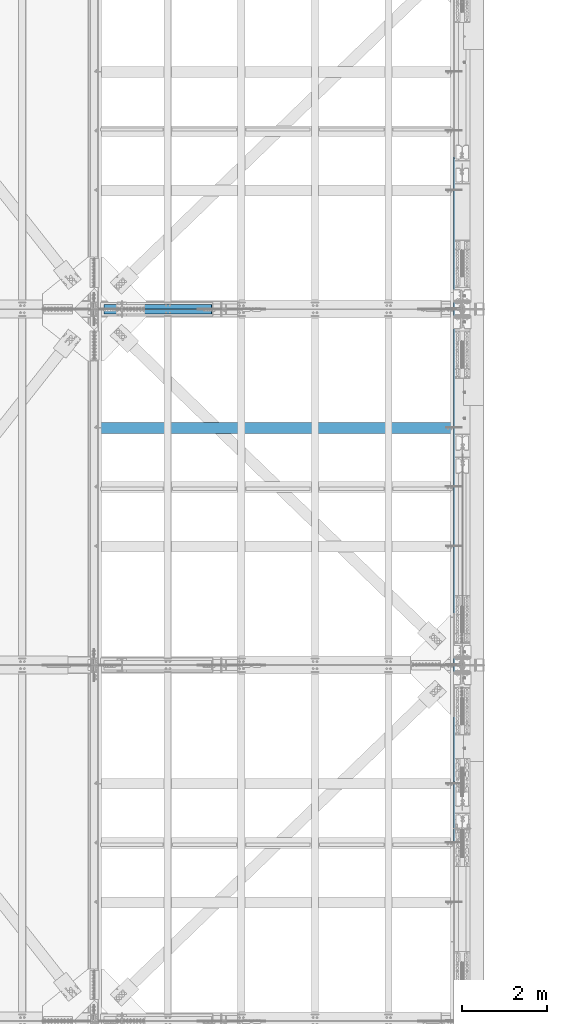
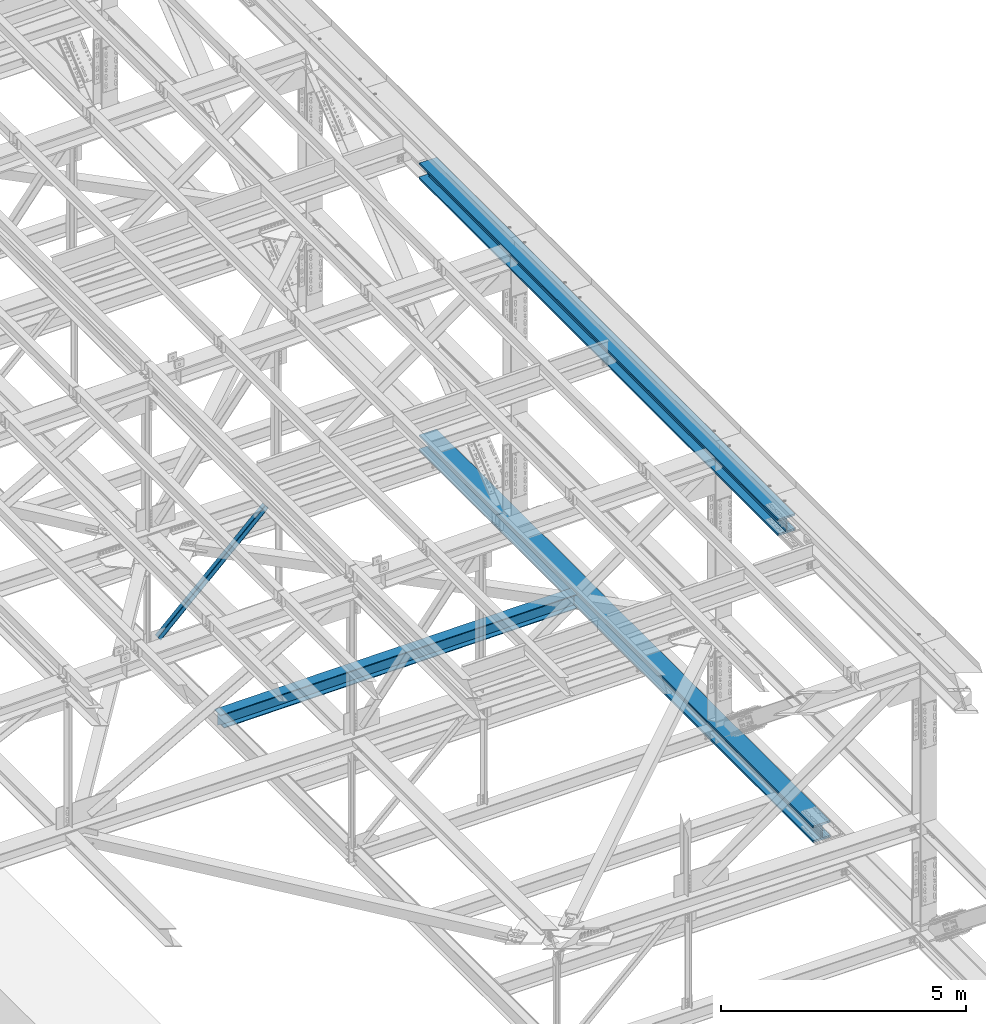
# One storey, part 1971 of 3843: 3 beams, 2 members, 5 elements without a shape of their own.
"""IFC2X3 building model written with IfcOpenShell, lengths in millimetres."""

from ifc_helpers import new_model, si_unit, frame, origin_with_axes, place, context, subcontext, project, spatial, faceted_brep, material, type_object, element, aggregate, save


model = new_model("IFC2X3")

# Units and contexts
model_context = context("Model", 3, precision=1e-05, world=origin_with_axes())
body_context = subcontext(model_context, "Body", "Model", "MODEL_VIEW")
ifc_project = project(units=[si_unit("LENGTHUNIT", "METRE", prefix="MILLI"), si_unit("AREAUNIT", "SQUARE_METRE"), si_unit("VOLUMEUNIT", "CUBIC_METRE"), si_unit("MASSUNIT", "GRAM", prefix="KILO"), si_unit("TIMEUNIT", "SECOND"), si_unit("PLANEANGLEUNIT", "RADIAN"), si_unit("SOLIDANGLEUNIT", "STERADIAN"), si_unit("THERMODYNAMICTEMPERATUREUNIT", "DEGREE_CELSIUS"), si_unit("LUMINOUSINTENSITYUNIT", "LUMEN")], contexts=[model_context])

# Site, building, storey
site_placement = place(None, origin_with_axes())
site = spatial("IfcSite", under=ifc_project, at=site_placement, CompositionType="ELEMENT")
building_placement = place(site_placement, origin_with_axes())
building = spatial("IfcBuilding", under=site, at=building_placement, Name="Undefined", CompositionType="ELEMENT")
storey_placement = place(building_placement, origin_with_axes())
storey = spatial("IfcBuildingStorey", under=building, at=storey_placement, Name="Undefined", CompositionType="ELEMENT", Elevation=0.0)

# Assembly, member
assembly_1_placement = place(storey_placement, origin_with_axes())
assembly_1 = element("IfcElementAssembly", 1, at=assembly_1_placement, inside=storey, Name="ANGLE", AssemblyPlace="NOTDEFINED", PredefinedType="RIGID_FRAME")
ifc_material_1 = material(Name="STEEL/A572-50")
member_type = type_object("IfcMemberType", Name="L4X4X3/8", PredefinedType="NOTDEFINED")
member_1_placement = place(assembly_1_placement, frame((80060.8, 58975.625, 42337.1940566244), z_axis=(0.0, 1.0, 0.0), x_axis=(-0.725652811134127, 0.0, -0.688061042127179)))
member_1 = element("IfcMember", 2, at=member_1_placement, type_object=member_type, material=ifc_material_1, Name="ANGLE", ObjectType="L4X4X3/8", context=body_context, shape_type="Brep", body=[
    faceted_brep([(356.597086186564, 50.7999999988533, -50.8000000000029), (356.597086186564, 50.7999999988533, 50.8000000000029), (3847.76029775629, 50.799999990355, 50.8000000000029), (3847.76029775629, 50.799999990355, -50.8000000000029), (356.597086186608, 41.2749999988991, 50.8000000000029), (3847.76029775634, 41.2749999904045, 50.8000000000029), (356.597086186608, 41.2749999988991, -41.2750000000015), (3847.76029775634, 41.2749999904045, -41.2750000000015), (356.597086187103, -50.8000000005777, -41.2750000000015), (3847.76029775682, -50.8000000090797, -41.2750000000015), (356.597086187103, -50.8000000005777, -50.8000000000029), (3847.76029775682, -50.8000000090797, -50.8000000000029)], [[[0, 1, 2, 3]], [[1, 4, 5, 2]], [[4, 6, 7, 5]], [[6, 8, 9, 7]], [[8, 10, 11, 9]], [[10, 0, 3, 11]], [[5, 7, 9, 11, 3, 2]], [[10, 8, 6, 4, 1, 0]]]),
])
aggregate(assembly_1, [member_1])

assembly_2_placement = place(storey_placement, origin_with_axes())
assembly_2 = element("IfcElementAssembly", 3, at=assembly_2_placement, inside=storey, Name="ANGLE", AssemblyPlace="NOTDEFINED", PredefinedType="RIGID_FRAME")
member_2_placement = place(assembly_2_placement, frame((77012.7999999773, 58854.975, 39447.0928644192), z_axis=(0.0, -1.0, 0.0), x_axis=(0.725652811134124, 0.0, 0.688061042127181)))
member_2 = element("IfcMember", 4, at=member_2_placement, type_object=member_type, material=ifc_material_1, Name="ANGLE", ObjectType="L4X4X3/8", context=body_context, shape_type="Brep", body=[
    faceted_brep([(352.595508753744, 50.8000000005777, -50.8000000000029), (352.595508753744, 50.8000000005777, 50.8000000000029), (3843.75872032347, 50.800000009076, 50.8000000000029), (3843.75872032347, 50.800000009076, -50.8000000000029), (352.5955087537, 41.2750000006308, 50.8000000000029), (3843.75872032343, 41.2750000091219, 50.8000000000029), (352.5955087537, 41.2750000006308, -41.2750000000015), (3843.75872032343, 41.2750000091219, -41.2750000000015), (352.59550875322, -50.7999999988569, -41.2750000000015), (3843.75872032293, -50.799999990355, -41.2750000000015), (352.59550875322, -50.7999999988569, -50.8000000000029), (3843.75872032293, -50.799999990355, -50.8000000000029)], [[[0, 1, 2, 3]], [[1, 4, 5, 2]], [[4, 6, 7, 5]], [[6, 8, 9, 7]], [[8, 10, 11, 9]], [[10, 0, 3, 11]], [[5, 7, 9, 11, 3, 2]], [[10, 8, 6, 4, 1, 0]]]),
])
aggregate(assembly_2, [member_2])

# Assembly, beam
assembly_3_placement = place(storey_placement, origin_with_axes())
assembly_3 = element("IfcElementAssembly", 5, at=assembly_3_placement, inside=storey, Name="BEAM", AssemblyPlace="NOTDEFINED", PredefinedType="RIGID_FRAME")
ifc_material_2 = material(Name="STEEL/A992")
beam_type_1 = type_object("IfcBeamType", Name="W14X257", PredefinedType="NOTDEFINED")
beam_1_placement = place(assembly_3_placement, frame((85648.8, 46380.8355605084, 39539.440733744), z_axis=(0.0, -0.000749054000341859, 0.999999719459013), x_axis=(0.0, 0.999999719459013, 0.000749054000343971)))
beam_1 = element("IfcBeam", 6, at=beam_1_placement, type_object=beam_type_1, material=ifc_material_2, Name="BEAM", ObjectType="W14X257", context=body_context, shape_type="Brep", body=[
    faceted_brep([(16102.837351816, -15.0812500000029, -125.809682712184), (16102.9185206105, 15.0811407847359, -125.809844284049), (16085.3748864122, -15.0812500000029, -125.774922518394), (16103.3382151813, 14.9415890320815, 125.808856636053), (16085.8757257498, -15.0812500000029, 125.831546048721), (16103.38466943, 15.0812500000029, 160.337354900956), (16103.38466943, 203.199999999997, 160.337354900956), (16076.4612632891, 203.199999999997, 207.99498957899), (16076.4612632891, -203.199999999997, 207.99498957899), (16103.38466943, -203.199999999997, 160.337354900956), (16103.3798207876, -15.0812500000029, 160.336831859837), (16075.9016830329, -203.199999999997, -207.929633995504), (16075.9016830329, 203.199999999997, -207.929633995504), (16102.9532373241, 203.199999999997, -160.337354877862), (16102.9532373241, 15.0812500000029, -160.337354877862), (16102.9532373241, -15.0812500000029, -160.337354877862), (16102.9532373241, -203.199999999997, -160.337354877862), (16036.7326161894, 15.0812500000029, -160.257171663849), (16036.7326161894, -15.0812500000029, -160.257171663849), (16004.2761256388, 15.0812500000029, -143.670504589463), (16004.2761256388, -15.0812500000029, -143.670504589463), (16000.559169498, 15.0812500000029, -140.283631484395), (16000.559169498, -15.0812500000029, -140.283631484395), (15999.0848318641, 15.0812500000029, -135.476033235442), (15999.0848318641, -15.0812500000029, -135.476033235442), (16000.2640340806, 15.0812500000029, -130.587663925049), (16000.2640340806, -15.0812500000029, -130.587663925049), (16003.768113738, 15.0812500000029, -126.980989814947), (16003.768113738, -15.0812500000029, -126.980989814947), (16008.620428114, 15.0812500000029, -125.661248332966), (16008.620428114, -15.0812500000029, -125.661248332966), (16102.9996901676, 15.0812500000029, -125.809901120359), (12882.7039695418, 203.199999999997, 211.428833744212), (12882.7039695418, -203.199999999997, 211.428833744212), (14493.0765897143, -203.199999999997, 209.912230311049), (14493.0765897143, 203.199999999997, 209.912230311049), (11272.330999583, 203.199999999997, 212.512121988402), (11272.330999583, -203.199999999997, 212.512121988402), (9661.95779643343, 203.199999999997, 213.162094966305), (9661.95779643343, -203.199999999997, 213.162094966305), (8051.5844766884, 203.199999999997, 213.37875263043), (8051.5844766884, -203.199999999997, 213.37875263043), (6441.21115694335, 203.199999999997, 213.162094963998), (6441.21115694335, -203.199999999997, 213.162094963998), (4830.83795379374, 203.199999999997, 212.512121983782), (4830.83795379374, -203.199999999997, 212.512121983782), (3220.46498383498, 203.199999999997, 211.428833737285), (3220.46498383498, -203.199999999997, 211.428833737285), (1610.09236366248, 203.199999999997, 209.912230301816), (1610.09236366248, -203.199999999997, 209.912230301816), (6.07020808529342, 203.199999999997, 207.970000680194), (6.07020808529342, -203.199999999997, 207.970000680194), (6.13428285813279, -203.199999999997, 160.345043783193), (1610.14362292821, -203.199999999997, 162.287257887161), (3220.50342828753, -203.199999999997, 163.803849254014), (4830.86358343033, -203.199999999997, 164.887128880058), (6441.22397176213, -203.199999999997, 165.537096687993), (8051.58447668843, -203.199999999997, 165.753752630335), (9661.94498161472, -203.199999999997, 165.537096690306), (11272.3053699465, -203.199999999997, 164.887128884671), (12882.6655250893, -203.199999999997, 163.803849260941), (14493.0253304486, -203.199999999997, 162.287257896394), (16037.3243701048, -203.199999999997, 160.417343989364), (16037.3243701048, 203.199999999997, 160.417343989364), (14493.0253304486, 203.199999999997, 162.287257896394), (12882.6655250893, 203.199999999997, 163.803849260941), (11272.3053699465, 203.199999999997, 164.887128884671), (9661.94498161472, 203.199999999997, 165.537096690306), (8051.58447668843, 203.199999999997, 165.753752630335), (6441.22397176213, 203.199999999997, 165.537096687993), (4830.86358343033, 203.199999999997, 164.887128880058), (3220.50342828753, 203.199999999997, 163.803849254014), (1610.14362292821, 203.199999999997, 162.287257887161), (6.13428285813279, 203.199999999997, 160.345043783193), (12882.6655250893, 15.0812500000029, 163.803849260941), (14493.0253304486, 15.0812500000029, 162.287257896394), (11272.3053699465, 15.0812500000029, 164.887128884671), (9661.94498161472, 15.0812500000029, 165.537096690306), (8051.58447668843, 15.0812500000029, 165.753752630335), (6441.22397176213, 15.0812500000029, 165.537096687993), (4830.86358343033, 15.0812500000029, 164.887128880058), (3220.50342828753, 15.0812500000029, 163.803849254014), (1610.14362292821, 15.0812500000029, 162.287257887161), (6.13428285813279, 15.0812500000029, 160.345043783193), (1610.48876865084, 15.0812500000029, -158.387556371483), (1610.48876865084, 203.199999999997, -158.387556371483), (6.56571966187039, 203.199999999997, -160.329665989928), (6.56571966187039, 15.0812500000029, -160.329665989928), (3220.76228760143, 15.0812500000029, -156.871046266744), (3220.76228760143, 203.199999999997, -156.871046266744), (4831.03615631675, 15.0812500000029, -155.78782468506), (4831.03615631675, 203.199999999997, -155.78782468506), (6441.31025820858, 15.0812500000029, -155.137891703736), (6441.31025820858, 203.199999999997, -155.137891703736), (8051.58447668867, 15.0812500000029, -154.921247370272), (8051.58447668867, 203.199999999997, -154.921247370272), (9661.85869516875, 15.0812500000029, -155.13789170143), (9661.85869516875, 203.199999999997, -155.13789170143), (11272.1327970606, 15.0812500000029, -155.787824680439), (11272.1327970606, 203.199999999997, -155.787824680439), (12882.4066657759, 15.0812500000029, -156.871046259817), (12882.4066657759, 203.199999999997, -156.871046259817), (14492.6801847265, 15.0812500000029, -158.38755636225), (14492.6801847265, 203.199999999997, -158.38755636225), (12882.3682213234, -203.199999999997, -204.496030743096), (12882.3682213234, 203.199999999997, -204.496030743096), (14492.6289254608, 203.199999999997, -206.012528776904), (14492.6289254608, -203.199999999997, -206.012528776904), (11272.107167424, -203.199999999997, -203.41281778417), (11272.107167424, 203.199999999997, -203.41281778417), (9661.84588035003, -203.199999999997, -202.762889977421), (9661.84588035003, 203.199999999997, -202.762889977421), (8051.58447668869, -203.199999999997, -202.546247370359), (8051.58447668869, 203.199999999997, -202.546247370359), (6441.32307302735, -203.199999999997, -202.762889979735), (6441.32307302735, 203.199999999997, -202.762889979735), (4831.06178595334, -203.199999999997, -203.412817788791), (4831.06178595334, 203.199999999997, -203.412817788791), (3220.80073205399, -203.199999999997, -204.496030750015), (3220.80073205399, 203.199999999997, -204.496030750015), (1610.54002791658, -203.199999999997, -206.012528786137), (1610.54002791658, 203.199999999997, -206.012528786137), (6.62979443470977, -203.199999999997, -207.954622886922), (6.62979443470977, 203.199999999997, -207.954622886922), (16036.7326161894, 203.199999999997, -160.257171663849), (16036.7326161894, -203.199999999997, -160.257171663849), (14492.6801847265, -203.199999999997, -158.38755636225), (12882.4066657759, -203.199999999997, -156.871046259817), (11272.1327970606, -203.199999999997, -155.787824680439), (9661.85869516875, -203.199999999997, -155.13789170143), (8051.58447668867, -203.199999999997, -154.921247370272), (6441.31025820858, -203.199999999997, -155.137891703736), (4831.03615631675, -203.199999999997, -155.78782468506), (3220.76228760143, -203.199999999997, -156.871046266744), (1610.48876865084, -203.199999999997, -158.387556371483), (6.56571966187039, -203.199999999997, -160.329665989928), (12882.4066657759, -15.0812500000029, -156.871046259817), (14492.6801847265, -15.0812500000029, -158.38755636225), (11272.1327970606, -15.0812500000029, -155.787824680439), (9661.85869516875, -15.0812500000029, -155.13789170143), (8051.58447668867, -15.0812500000029, -154.921247370272), (6441.31025820858, -15.0812500000029, -155.137891703736), (4831.03615631675, -15.0812500000029, -155.78782468506), (3220.76228760143, -15.0812500000029, -156.871046266744), (1610.48876865084, -15.0812500000029, -158.387556371483), (6.56571966187039, -15.0812500000029, -160.329665989928), (6.13428285813279, -15.0812500000029, 160.345043783193), (1610.14362292821, -15.0812500000029, 162.287257887161), (3220.50342828753, -15.0812500000029, 163.803849254014), (4830.86358343033, -15.0812500000029, 164.887128880058), (6441.22397176213, -15.0812500000029, 165.537096687993), (8051.58447668843, -15.0812500000029, 165.753752630335), (9661.94498161472, -15.0812500000029, 165.537096690306), (11272.3053699465, -15.0812500000029, 164.887128884671), (12882.6655250893, -15.0812500000029, 163.803849260941), (14493.0253304486, -15.0812500000029, 162.287257896394), (16037.3243701048, -15.0812500000029, 160.417343989364), (16037.3243701048, 15.0812500000029, 160.417343989364), (16004.8203771915, -15.0812500000029, 143.952956454967), (16004.8203771915, 15.0812500000029, 143.952956454967), (16001.0936999411, -15.0812500000029, 140.576782725228), (16001.0936999411, 15.0812500000029, 140.576782725228), (15999.605547678, -15.0812500000029, 135.773442718128), (15999.605547678, 15.0812500000029, 135.773442718128), (16000.7706921025, -15.0812500000029, 130.881703676438), (16000.7706921025, 15.0812500000029, 130.881703676438), (16004.2643889353, -15.0812500000029, 127.264971059536), (16004.2643889353, 15.0812500000029, 127.264971059536), (16009.1128893124, -15.0812500000029, 125.9312857611), (16009.1128893124, 15.0812500000029, 125.9312857611), (16103.3382151813, 15.0812500000029, 125.808856636053)], [[[0, 1, 2]], [[2, 1, 3, 4]], [[5, 6, 7, 8, 9]], [[10, 5, 9]], [[11, 12, 13, 14, 15, 16]], [[15, 14, 17, 18]], [[18, 17, 19, 20]], [[20, 19, 21, 22]], [[22, 21, 23, 24]], [[24, 23, 25, 26]], [[26, 25, 27, 28]], [[28, 27, 29, 30]], [[0, 30, 29, 31]], [[32, 33, 34, 35]], [[36, 37, 33, 32]], [[38, 39, 37, 36]], [[40, 41, 39, 38]], [[42, 43, 41, 40]], [[44, 45, 43, 42]], [[46, 47, 45, 44]], [[48, 49, 47, 46]], [[49, 48, 50, 51]], [[34, 33, 37, 39, 41, 43, 45, 47, 49, 51, 52, 53, 54, 55, 56, 57, 58, 59, 60, 61, 62, 9, 8]], [[35, 34, 8, 7]], [[63, 64, 65, 66, 67, 68, 69, 70, 71, 72, 73, 50, 48, 46, 44, 42, 40, 38, 36, 32, 35, 7, 6]], [[74, 65, 64, 75]], [[76, 66, 65, 74]], [[77, 67, 66, 76]], [[78, 68, 67, 77]], [[79, 69, 68, 78]], [[80, 70, 69, 79]], [[81, 71, 70, 80]], [[82, 72, 71, 81]], [[72, 82, 83, 73]], [[84, 85, 86, 87]], [[85, 84, 88, 89]], [[89, 88, 90, 91]], [[91, 90, 92, 93]], [[93, 92, 94, 95]], [[95, 94, 96, 97]], [[97, 96, 98, 99]], [[99, 98, 100, 101]], [[101, 100, 102, 103]], [[104, 105, 106, 107]], [[108, 109, 105, 104]], [[110, 111, 109, 108]], [[112, 113, 111, 110]], [[114, 115, 113, 112]], [[116, 117, 115, 114]], [[118, 119, 117, 116]], [[120, 121, 119, 118]], [[121, 120, 122, 123]], [[106, 105, 109, 111, 113, 115, 117, 119, 121, 123, 86, 85, 89, 91, 93, 95, 97, 99, 101, 103, 124, 13, 12]], [[107, 106, 12, 11]], [[125, 126, 127, 128, 129, 130, 131, 132, 133, 134, 135, 122, 120, 118, 116, 114, 112, 110, 108, 104, 107, 11, 16]], [[136, 127, 126, 137]], [[138, 128, 127, 136]], [[139, 129, 128, 138]], [[140, 130, 129, 139]], [[141, 131, 130, 140]], [[142, 132, 131, 141]], [[143, 133, 132, 142]], [[144, 134, 133, 143]], [[134, 144, 145, 135]], [[146, 52, 51, 50, 73, 83, 87, 86, 123, 122, 135, 145]], [[147, 53, 52, 146]], [[53, 147, 148, 54]], [[54, 148, 149, 55]], [[55, 149, 150, 56]], [[56, 150, 151, 57]], [[57, 151, 152, 58]], [[58, 152, 153, 59]], [[59, 153, 154, 60]], [[60, 154, 155, 61]], [[62, 61, 155, 156, 10, 9]], [[157, 75, 64, 63, 6, 5]], [[10, 156, 157, 5]], [[158, 159, 157, 156]], [[160, 161, 159, 158]], [[162, 163, 161, 160]], [[164, 165, 163, 162]], [[166, 167, 165, 164]], [[168, 169, 167, 166]], [[170, 169, 168, 4, 3]], [[0, 31, 170, 3, 1]], [[27, 25, 23, 21, 19, 17, 102, 100, 98, 96, 94, 92, 90, 88, 84, 87, 83, 82, 81, 80, 79, 78, 77, 76, 74, 75, 157, 159, 161, 163, 165, 167, 169, 170, 31, 29]], [[124, 103, 102, 17, 14, 13]], [[18, 137, 126, 125, 16, 15]], [[168, 166, 164, 162, 160, 158, 156, 155, 154, 153, 152, 151, 150, 149, 148, 147, 146, 145, 144, 143, 142, 141, 140, 139, 138, 136, 137, 18, 20, 22, 24, 26, 28, 30, 0, 2, 4]]]),
])
aggregate(assembly_3, [beam_1])

assembly_4_placement = place(storey_placement, origin_with_axes())
assembly_4 = element("IfcElementAssembly", 7, at=assembly_4_placement, inside=storey, Name="BEAM", AssemblyPlace="NOTDEFINED", PredefinedType="RIGID_FRAME")
beam_2_placement = place(assembly_4_placement, frame((85648.8, 47815.8850270906, 46314.5493275734), z_axis=(0.0, -0.000625967000050877, 0.999999804082638), x_axis=(0.0, 0.999999804686856, 0.000625000999804019)))
beam_2 = element("IfcBeam", 8, at=beam_2_placement, type_object=beam_type_1, material=ifc_material_2, Name="BEAM", ObjectType="W14X257", context=body_context, shape_type="Brep", body=[
    faceted_brep([(14667.6777158349, -15.0812500000029, -125.809671775998), (14667.7583537604, 15.0811422087136, -125.809822281815), (14650.2152462511, -15.0812500000029, -125.777079128115), (14668.147346798, 14.9424989989202, 125.808927607592), (14650.6848547186, -15.0812500000029, 125.82946761667), (14668.1896608039, 15.0812500000029, 160.337379559642), (14668.1896608039, 203.199999999997, 160.337379559642), (14641.2605407681, 203.199999999997, 207.992109209474), (14641.2605407681, -203.199999999997, 207.992109209474), (14668.1896608039, -203.199999999997, 160.337379559642), (14668.1849638781, -15.0812500000029, 160.336907396879), (14640.7508324354, -203.199999999997, -207.932578470405), (14640.7508324354, 203.199999999997, -207.932578470405), (14667.7966795702, 203.199999999997, -160.337379643934), (14667.7966795702, 15.0812500000029, -160.337379643934), (14667.7966795702, -15.0812500000029, -160.337379643934), (14667.7966795702, -203.199999999997, -160.337379643934), (14601.5772214211, 15.0812500000029, -160.264343955845), (14601.5772214211, -15.0812500000029, -160.264343955845), (14569.1186888407, 15.0812500000029, -143.682625126341), (14569.1186888407, -15.0812500000029, -143.682625126341), (14565.401315848, 15.0812500000029, -140.296209556043), (14565.401315848, -15.0812500000029, -140.296209556043), (14563.9263864723, 15.0812500000029, -135.488792815391), (14563.9263864723, -15.0812500000029, -135.488792815391), (14565.104986985, 15.0812500000029, -130.600278397571), (14565.104986985, -15.0812500000029, -130.600278397571), (14568.608622681, 15.0812500000029, -126.993173008057), (14568.608622681, -15.0812500000029, -126.993173008057), (14573.4607745771, 15.0812500000029, -125.672834279139), (14573.4607745771, -15.0812500000029, -125.672834279139), (14667.838992422, 15.0812500000029, -125.809869417586), (11734.5481535854, 203.199999999997, 210.838501036014), (11734.5481535854, -203.199999999997, 210.838501036014), (13201.3982652033, -203.199999999997, 209.580182186597), (13201.3982652033, 203.199999999997, 209.580182186597), (10267.6977776166, 203.199999999997, 211.737300268724), (10267.6977776166, -203.199999999997, 211.737300268724), (8800.84722541383, 203.199999999997, 212.276579832564), (8800.84722541383, -203.199999999997, 212.276579832564), (7333.99658509414, 203.199999999997, 212.456339693097), (7333.99658509414, -203.199999999997, 212.456339693097), (5867.14594477445, 203.199999999997, 212.276579840996), (5867.14594477445, -203.199999999997, 212.276579840996), (4400.29539257173, 203.199999999997, 211.737300285575), (4400.29539257173, -203.199999999997, 211.737300285575), (2933.44501660292, 203.199999999997, 210.838501061298), (2933.44501660292, -203.199999999997, 210.838501061298), (1466.59490498497, 203.199999999997, 209.580182220314), (1466.59490498497, -203.199999999997, 209.580182220314), (6.09514311786916, 203.199999999997, 207.969347467442), (6.09514311786916, -203.199999999997, 207.969347467442), (6.15366013223684, -203.199999999997, 160.344383398551), (1466.64159582857, -203.199999999997, 161.955205107944), (2933.48003473804, -203.199999999997, 163.21351393564), (4400.31873799627, -203.199999999997, 164.11230600757), (5867.157617487, -203.199999999997, 164.651581271588), (7333.99658509401, -203.199999999997, 164.831339693214), (8800.83555270101, -203.199999999997, 164.651581263148), (10267.6744321918, -203.199999999997, 164.112305990711), (11734.51313545, -203.199999999997, 163.213513910348), (13201.3515743594, -203.199999999997, 161.95520507422), (14602.1295047749, -203.199999999997, 160.410239548008), (14602.1295047749, 203.199999999997, 160.410239548008), (13201.3515743594, 203.199999999997, 161.95520507422), (11734.51313545, 203.199999999997, 163.213513910348), (10267.6744321918, 203.199999999997, 164.112305990711), (8800.83555270101, 203.199999999997, 164.651581263148), (7333.99658509401, 203.199999999997, 164.831339693214), (5867.157617487, 203.199999999997, 164.651581271588), (4400.31873799627, 203.199999999997, 164.11230600757), (2933.48003473804, 203.199999999997, 163.21351393564), (1466.64159582857, 203.199999999997, 161.955205107944), (6.15366013223684, 203.199999999997, 160.344383398551), (11734.51313545, 15.0812500000029, 163.213513910348), (13201.3515743594, 15.0812500000029, 161.95520507422), (10267.6744321918, 15.0812500000029, 164.112305990711), (8800.83555270101, 15.0812500000029, 164.651581263148), (7333.99658509401, 15.0812500000029, 164.831339693214), (5867.157617487, 15.0812500000029, 164.651581271588), (4400.31873799627, 15.0812500000029, 164.11230600757), (2933.48003473804, 15.0812500000029, 163.21351393564), (1466.64159582857, 15.0812500000029, 161.955205107944), (6.15366013223684, 15.0812500000029, 160.344383398551), (1466.95598084217, 15.0812500000029, -158.719640782067), (1466.95598084217, 203.199999999997, -158.719640782067), (6.54767469568469, 203.199999999997, -160.330374665326), (6.54767469568469, 15.0812500000029, -160.330374665326), (2933.71582351453, 15.0812500000029, -157.461399377164), (2933.71582351453, 203.199999999997, -157.461399377164), (4400.47593052149, 15.0812500000029, -156.562655464368), (4400.47593052149, 203.199999999997, -156.562655464368), (5867.23621375152, 15.0812500000029, -156.02340909584), (5867.23621375152, 203.199999999997, -156.02340909584), (7333.99658509309, 15.0812500000029, -155.843660306033), (7333.99658509309, 203.199999999997, -155.843660306033), (8800.75695643465, 15.0812500000029, -156.023409104266), (8800.75695643465, 203.199999999997, -156.023409104266), (10267.5172396647, 15.0812500000029, -156.562655481226), (10267.5172396647, 203.199999999997, -156.562655481226), (11734.2773466716, 15.0812500000029, -157.461399402448), (11734.2773466716, 203.199999999997, -157.461399402448), (13201.037189344, 15.0812500000029, -158.719640815783), (13201.037189344, 203.199999999997, -158.719640815783), (11734.2423285362, -203.199999999997, -205.086386528106), (11734.2423285362, 203.199999999997, -205.086386528106), (13200.9904985001, 203.199999999997, -206.34461792816), (13200.9904985001, -203.199999999997, -206.34461792816), (10267.4938942399, -203.199999999997, -204.187649759238), (10267.4938942399, 203.199999999997, -204.187649759238), (8800.74528372182, -203.199999999997, -203.648407673689), (8800.74528372182, 203.199999999997, -203.648407673689), (7333.99658509295, -203.199999999997, -203.468660305924), (7333.99658509295, 203.199999999997, -203.468660305924), (5867.24788646407, -203.199999999997, -203.648407665256), (5867.24788646407, 203.199999999997, -203.648407665256), (4400.49927594602, -203.199999999997, -204.18764974238), (4400.49927594602, 203.199999999997, -204.18764974238), (2933.75084164966, -203.199999999997, -205.086386502822), (2933.75084164966, 203.199999999997, -205.086386502822), (1467.00267168578, -203.199999999997, -206.34461789445), (1467.00267168578, 203.199999999997, -206.34461789445), (6.6061917100451, -203.199999999997, -207.955338734224), (6.6061917100451, 203.199999999997, -207.955338734224), (14601.5772214211, 203.199999999997, -160.264343955845), (14601.5772214211, -203.199999999997, -160.264343955845), (13201.037189344, -203.199999999997, -158.719640815783), (11734.2773466716, -203.199999999997, -157.461399402448), (10267.5172396647, -203.199999999997, -156.562655481226), (8800.75695643465, -203.199999999997, -156.023409104266), (7333.99658509309, -203.199999999997, -155.843660306033), (5867.23621375152, -203.199999999997, -156.02340909584), (4400.47593052149, -203.199999999997, -156.562655464368), (2933.71582351453, -203.199999999997, -157.461399377164), (1466.95598084217, -203.199999999997, -158.719640782067), (6.54767469568469, -203.199999999997, -160.330374665326), (11734.2773466716, -15.0812500000029, -157.461399402448), (13201.037189344, -15.0812500000029, -158.719640815783), (10267.5172396647, -15.0812500000029, -156.562655481226), (8800.75695643465, -15.0812500000029, -156.023409104266), (7333.99658509309, -15.0812500000029, -155.843660306033), (5867.23621375152, -15.0812500000029, -156.02340909584), (4400.47593052149, -15.0812500000029, -156.562655464368), (2933.71582351453, -15.0812500000029, -157.461399377164), (1466.95598084217, -15.0812500000029, -158.719640782067), (6.54767469568469, -15.0812500000029, -160.330374665326), (6.15366013223684, -15.0812500000029, 160.344383398551), (1466.64159582857, -15.0812500000029, 161.955205107944), (2933.48003473804, -15.0812500000029, 163.21351393564), (4400.31873799627, -15.0812500000029, 164.11230600757), (5867.157617487, -15.0812500000029, 164.651581271588), (7333.99658509401, -15.0812500000029, 164.831339693214), (8800.83555270101, -15.0812500000029, 164.651581263148), (10267.6744321918, -15.0812500000029, 164.112305990711), (11734.51313545, -15.0812500000029, 163.213513910348), (13201.3515743594, -15.0812500000029, 161.95520507422), (14602.1295047749, -15.0812500000029, 160.410239548008), (14602.1295047749, 15.0812500000029, 160.410239548008), (14569.627537672, -15.0812500000029, 143.940900727153), (14569.627537672, 15.0812500000029, 143.940900727153), (14565.901276013, -15.0812500000029, 140.564268317386), (14565.901276013, 15.0812500000029, 140.564268317386), (14564.4137149901, -15.0812500000029, 135.760745174477), (14564.4137149901, 15.0812500000029, 135.760745174477), (14565.5794615153, -15.0812500000029, 130.869149584039), (14565.5794615153, 15.0812500000029, 130.869149584039), (14569.0736034946, -15.0812500000029, 127.252847023345), (14569.0736034946, 15.0812500000029, 127.252847023345), (14573.9222679942, -15.0812500000029, 125.919758522519), (14573.9222679942, 15.0812500000029, 125.919758522519), (14668.147346798, 15.0812500000029, 125.808927607592)], [[[0, 1, 2]], [[2, 1, 3, 4]], [[5, 6, 7, 8, 9]], [[10, 5, 9]], [[11, 12, 13, 14, 15, 16]], [[15, 14, 17, 18]], [[18, 17, 19, 20]], [[20, 19, 21, 22]], [[22, 21, 23, 24]], [[24, 23, 25, 26]], [[26, 25, 27, 28]], [[28, 27, 29, 30]], [[0, 30, 29, 31]], [[32, 33, 34, 35]], [[36, 37, 33, 32]], [[38, 39, 37, 36]], [[40, 41, 39, 38]], [[42, 43, 41, 40]], [[44, 45, 43, 42]], [[46, 47, 45, 44]], [[48, 49, 47, 46]], [[49, 48, 50, 51]], [[34, 33, 37, 39, 41, 43, 45, 47, 49, 51, 52, 53, 54, 55, 56, 57, 58, 59, 60, 61, 62, 9, 8]], [[35, 34, 8, 7]], [[63, 64, 65, 66, 67, 68, 69, 70, 71, 72, 73, 50, 48, 46, 44, 42, 40, 38, 36, 32, 35, 7, 6]], [[74, 65, 64, 75]], [[76, 66, 65, 74]], [[77, 67, 66, 76]], [[78, 68, 67, 77]], [[79, 69, 68, 78]], [[80, 70, 69, 79]], [[81, 71, 70, 80]], [[82, 72, 71, 81]], [[72, 82, 83, 73]], [[84, 85, 86, 87]], [[85, 84, 88, 89]], [[89, 88, 90, 91]], [[91, 90, 92, 93]], [[93, 92, 94, 95]], [[95, 94, 96, 97]], [[97, 96, 98, 99]], [[99, 98, 100, 101]], [[101, 100, 102, 103]], [[104, 105, 106, 107]], [[108, 109, 105, 104]], [[110, 111, 109, 108]], [[112, 113, 111, 110]], [[114, 115, 113, 112]], [[116, 117, 115, 114]], [[118, 119, 117, 116]], [[120, 121, 119, 118]], [[121, 120, 122, 123]], [[106, 105, 109, 111, 113, 115, 117, 119, 121, 123, 86, 85, 89, 91, 93, 95, 97, 99, 101, 103, 124, 13, 12]], [[107, 106, 12, 11]], [[125, 126, 127, 128, 129, 130, 131, 132, 133, 134, 135, 122, 120, 118, 116, 114, 112, 110, 108, 104, 107, 11, 16]], [[136, 127, 126, 137]], [[138, 128, 127, 136]], [[139, 129, 128, 138]], [[140, 130, 129, 139]], [[141, 131, 130, 140]], [[142, 132, 131, 141]], [[143, 133, 132, 142]], [[144, 134, 133, 143]], [[134, 144, 145, 135]], [[146, 52, 51, 50, 73, 83, 87, 86, 123, 122, 135, 145]], [[147, 53, 52, 146]], [[53, 147, 148, 54]], [[54, 148, 149, 55]], [[55, 149, 150, 56]], [[56, 150, 151, 57]], [[57, 151, 152, 58]], [[58, 152, 153, 59]], [[59, 153, 154, 60]], [[60, 154, 155, 61]], [[62, 61, 155, 156, 10, 9]], [[157, 75, 64, 63, 6, 5]], [[10, 156, 157, 5]], [[158, 159, 157, 156]], [[160, 161, 159, 158]], [[162, 163, 161, 160]], [[164, 165, 163, 162]], [[166, 167, 165, 164]], [[168, 169, 167, 166]], [[170, 169, 168, 4, 3]], [[0, 31, 170, 3, 1]], [[27, 25, 23, 21, 19, 17, 102, 100, 98, 96, 94, 92, 90, 88, 84, 87, 83, 82, 81, 80, 79, 78, 77, 76, 74, 75, 157, 159, 161, 163, 165, 167, 169, 170, 31, 29]], [[124, 103, 102, 17, 14, 13]], [[18, 137, 126, 125, 16, 15]], [[168, 166, 164, 162, 160, 158, 156, 155, 154, 153, 152, 151, 150, 149, 148, 147, 146, 145, 144, 143, 142, 141, 140, 139, 138, 136, 137, 18, 20, 22, 24, 26, 28, 30, 0, 2, 4]]]),
])
aggregate(assembly_4, [beam_2])

assembly_5_placement = place(storey_placement, origin_with_axes())
assembly_5 = element("IfcElementAssembly", 9, at=assembly_5_placement, inside=storey, Name="BEAM", AssemblyPlace="NOTDEFINED", PredefinedType="RIGID_FRAME")
beam_type_2 = type_object("IfcBeamType", Name="W14X68", PredefinedType="NOTDEFINED")
beam_3_placement = place(assembly_5_placement, frame((77011.2455595812, 56129.237504, 39446.1932049179), z_axis=(-0.00874272599685357, 0.0, 0.999961781640751), x_axis=(0.99996178164075, 0.0, 0.00874272599685906)))
beam_3 = element("IfcBeam", 10, at=beam_3_placement, type_object=beam_type_2, material=ifc_material_2, Name="BEAM", ObjectType="W14X68", context=body_context, shape_type="Brep", body=[
    faceted_brep([(18.5345399647922, -5.55625000000146, -146.050000000054), (18.5345399647922, 5.55625000000146, -146.050000000054), (94.4569118349318, 5.55625000000146, -146.049999997376), (94.4569118349318, -5.55625000000146, -146.049999997376), (99.3169913531019, 5.55625000000146, -147.016729919989), (99.3169913531019, -5.55625000000146, -147.016729919989), (103.437167821379, 5.55625000000146, -149.769743820485), (103.437167821379, -5.55625000000146, -149.769743820485), (106.190181721948, 5.55625000000146, -153.889920288661), (106.190181721948, -5.55625000000146, -153.889920288661), (107.15691164459, 5.55625000000146, -158.749999999636), (107.15691164459, -5.55625000000146, -158.749999999636), (107.156911644604, -127.0, -158.749999806714), (107.15691164459, 127.0, -158.749999999636), (107.15691164443, 127.0, -177.799999999566), (107.15691164443, -127.0, -177.799999999566), (21.1994246961403, 5.55625000000146, 158.750000000429), (21.1994246961403, 127.0, 158.750000000429), (8423.36429156657, 127.0, 158.750000031323), (8423.36429156657, 5.55625000000146, 158.750000031323), (21.3659799918532, 127.0, 177.800000000469), (8423.53084686227, 127.0, 177.80000003137), (21.3659799918532, -127.0, 177.800000000469), (8423.53084686227, -127.0, 177.80000003137), (21.1994246961403, -127.0, 158.750000000429), (8423.36429156657, -127.0, 158.750000031323), (21.1994246961403, -5.55625000000146, 158.750000000429), (8423.36429156657, -5.55625000000146, 158.750000031323), (8420.58836997142, 5.55625000000146, -158.749999969383), (8420.58836997142, -5.55625000000146, -158.749999969383), (8420.58836997142, -127.0, -158.749999969383), (8420.4218146757, -127.0, -177.799999969422), (8420.4218146757, 127.0, -177.799999969422), (8420.58836997142, 127.0, -158.749999969383), (18.908174102995, 5.55625000000146, -103.315061415844), (20.9242467178701, 5.55625000000146, 127.276125431534)], [[[0, 1, 2, 3]], [[3, 2, 4, 5]], [[5, 4, 6, 7]], [[7, 6, 8, 9]], [[9, 8, 10, 11]], [[12, 11, 10, 13, 14, 15]], [[16, 17, 18, 19]], [[17, 20, 21, 18]], [[20, 22, 23, 21]], [[22, 24, 25, 23]], [[24, 26, 27, 25]], [[28, 19, 18, 21, 23, 25, 27, 29, 30, 31, 32, 33]], [[31, 30, 12, 15]], [[32, 31, 15, 14]], [[33, 32, 14, 13]], [[28, 33, 13, 10]], [[6, 4, 2, 1, 34, 35, 16, 19, 28, 10, 8]], [[26, 24, 22, 20, 17, 16, 35, 34, 1, 0]], [[29, 27, 26, 0, 3, 5, 7, 9, 11]], [[30, 29, 11, 12]]]),
])
aggregate(assembly_5, [beam_3])

save(model, "model.ifc")
